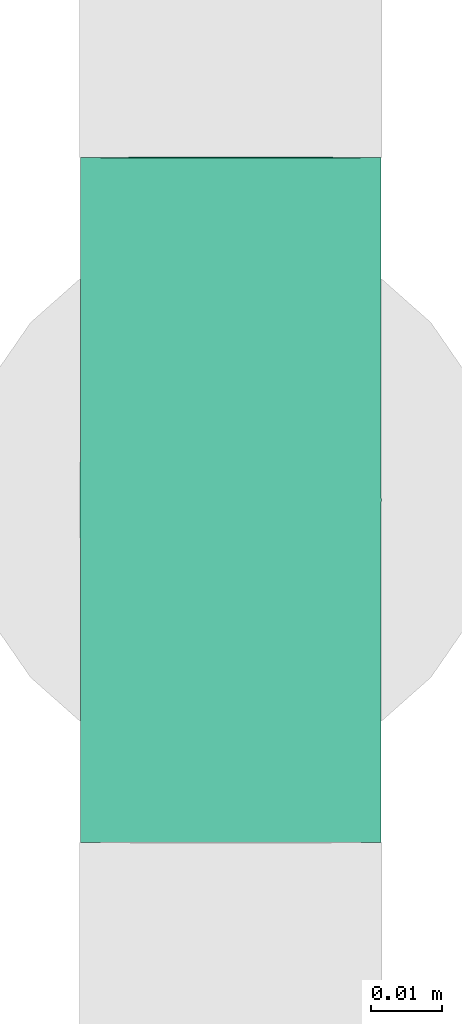
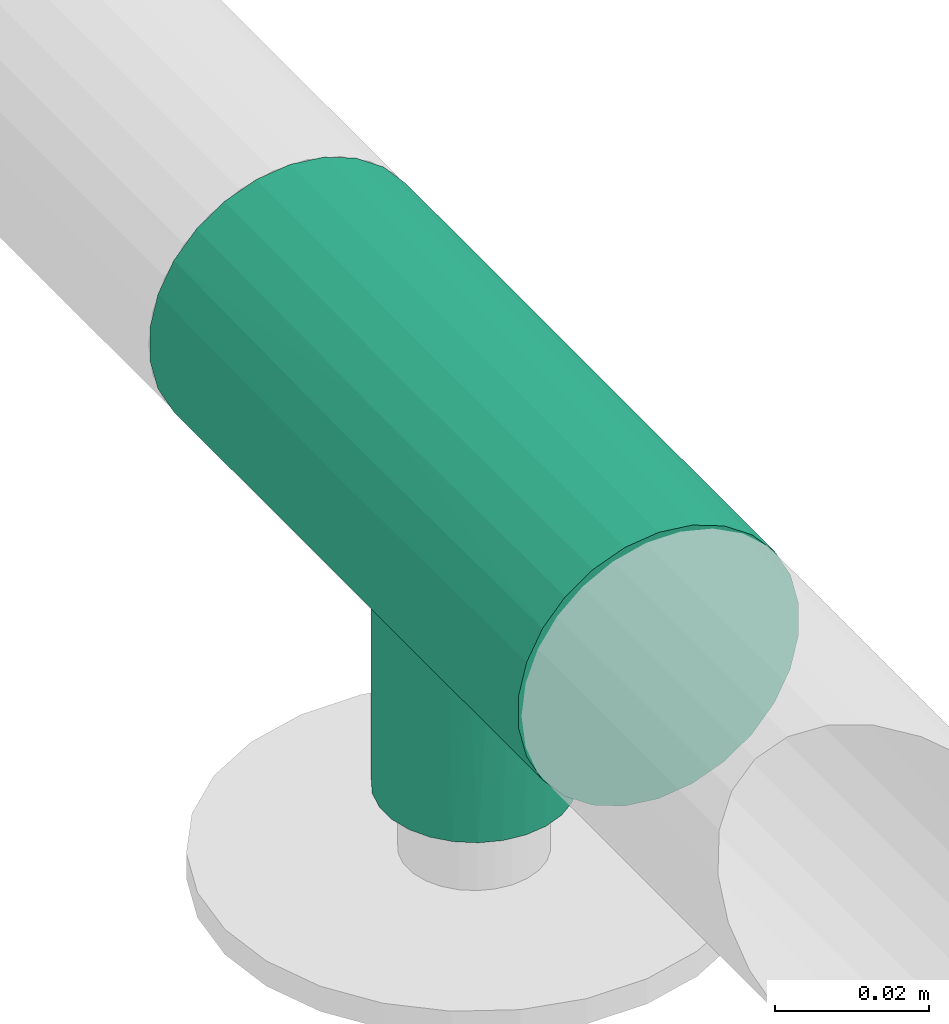
# One storey, part 6 of 7: 1 pipe fitting.
"""IFC4 building model written with IfcOpenShell, lengths in millimetres."""

from ifc_helpers import new_model, entity, si_unit, converted_unit, derived_unit, direction, frame, origin, place, context, subcontext, project, spatial, source, transform, mapped, type_object, type_shapes, element, save


model = new_model("IFC4")

# Units and contexts
model_context = context("Model", 3, precision=0.01, world=origin(), true_north=direction((6.12303176911189e-17, 1.0)))
body_context = subcontext(model_context, "Body", "Model", "MODEL_VIEW")
ifc_project = project(units=[si_unit("LENGTHUNIT", "METRE", prefix="MILLI"), si_unit("AREAUNIT", "SQUARE_METRE"), si_unit("VOLUMEUNIT", "CUBIC_METRE"), converted_unit("PLANEANGLEUNIT", "DEGREE", entity("IfcRatioMeasure", 0.0174532925199433), si_unit("PLANEANGLEUNIT", "RADIAN"), dimensions=[0, 0, 0, 0, 0, 0, 0]), si_unit("MASSUNIT", "GRAM", prefix="KILO"), derived_unit("MASSDENSITYUNIT", [(si_unit("MASSUNIT", "GRAM", prefix="KILO"), 1), (si_unit("LENGTHUNIT", "METRE"), -3)]), derived_unit("MOMENTOFINERTIAUNIT", [(si_unit("LENGTHUNIT", "METRE"), 4)]), si_unit("TIMEUNIT", "SECOND"), si_unit("FREQUENCYUNIT", "HERTZ"), si_unit("THERMODYNAMICTEMPERATUREUNIT", "DEGREE_CELSIUS"), derived_unit("THERMALTRANSMITTANCEUNIT", [(si_unit("MASSUNIT", "GRAM", prefix="KILO"), 1), (si_unit("THERMODYNAMICTEMPERATUREUNIT", "KELVIN"), -1), (si_unit("TIMEUNIT", "SECOND"), -3)]), derived_unit("VOLUMETRICFLOWRATEUNIT", [(si_unit("LENGTHUNIT", "METRE"), 3), (si_unit("TIMEUNIT", "SECOND"), -1)]), si_unit("ELECTRICCURRENTUNIT", "AMPERE"), si_unit("ELECTRICVOLTAGEUNIT", "VOLT"), si_unit("POWERUNIT", "WATT"), si_unit("FORCEUNIT", "NEWTON", prefix="KILO"), si_unit("ILLUMINANCEUNIT", "LUX"), si_unit("LUMINOUSFLUXUNIT", "LUMEN"), si_unit("LUMINOUSINTENSITYUNIT", "CANDELA"), derived_unit("USERDEFINED", [(si_unit("MASSUNIT", "GRAM", prefix="KILO"), -1), (si_unit("LENGTHUNIT", "METRE"), -2), (si_unit("TIMEUNIT", "SECOND"), 3), (si_unit("LUMINOUSFLUXUNIT", "LUMEN"), 1)]), derived_unit("LINEARVELOCITYUNIT", [(si_unit("LENGTHUNIT", "METRE"), 1), (si_unit("TIMEUNIT", "SECOND"), -1)]), si_unit("PRESSUREUNIT", "PASCAL"), derived_unit("USERDEFINED", [(si_unit("LENGTHUNIT", "METRE"), -2), (si_unit("MASSUNIT", "GRAM", prefix="KILO"), 1), (si_unit("TIMEUNIT", "SECOND"), -2)]), derived_unit("LINEARFORCEUNIT", [(si_unit("MASSUNIT", "GRAM", prefix="KILO"), 1), (si_unit("LENGTHUNIT", "METRE"), 1), (si_unit("TIMEUNIT", "SECOND"), -2), (si_unit("LENGTHUNIT", "METRE"), -1)]), derived_unit("PLANARFORCEUNIT", [(si_unit("MASSUNIT", "GRAM", prefix="KILO"), 1), (si_unit("LENGTHUNIT", "METRE"), 1), (si_unit("TIMEUNIT", "SECOND"), -2), (si_unit("LENGTHUNIT", "METRE"), -2)])], contexts=[model_context])

# Site, building, storey
site_placement = place(None, origin())
site = spatial("IfcSite", under=ifc_project, at=site_placement, CompositionType="ELEMENT")
building_placement = place(site_placement, origin())
building = spatial("IfcBuilding", under=site, at=building_placement, CompositionType="ELEMENT")
storey_placement = place(building_placement, origin())
storey = spatial("IfcBuildingStorey", under=building, at=storey_placement, Name="Ebene 1", CompositionType="ELEMENT", Elevation=0.0)

# Pipe fitting
pipe_fitting_type = type_object("IfcPipeFittingType", PredefinedType="NOTDEFINED")
cartesian_point_1 = entity("IfcCartesianPoint", [-48.0, -21.2, 0.0])
vertex_point_1 = entity("IfcVertexPoint", cartesian_point_1)
cartesian_point_2 = entity("IfcCartesianPoint", [-48.0, 21.2, 0.0])
vertex_point_2 = entity("IfcVertexPoint", cartesian_point_2)
cartesian_point_3 = entity("IfcCartesianPoint", [-48.0, 0.0, 0.0])
ifc_direction_1 = entity("IfcDirection", [-1.0, 0.0, 0.0])
ifc_direction_2 = entity("IfcDirection", [0.0, 1.0, 0.0])
edge_curve_1 = entity("IfcEdgeCurve", vertex_point_1, vertex_point_2, entity("IfcTrimmedCurve", entity("IfcCircle", entity("IfcAxis2Placement3D", cartesian_point_3, ifc_direction_1, ifc_direction_2), 21.2), [cartesian_point_1], [cartesian_point_2], True, "CARTESIAN"), True)
edge_curve_2 = entity("IfcEdgeCurve", vertex_point_2, vertex_point_1, entity("IfcTrimmedCurve", entity("IfcCircle", entity("IfcAxis2Placement3D", cartesian_point_3, ifc_direction_1, ifc_direction_2), 21.2), [cartesian_point_2], [cartesian_point_1], True, "CARTESIAN"), True)
ifc_direction_3 = entity("IfcDirection", [0.0, 0.0, 1.0])
cartesian_point_4 = entity("IfcCartesianPoint", [-13.5068310123159, -21.2, 0.0])
vertex_point_3 = entity("IfcVertexPoint", cartesian_point_4)
ifc_direction_4 = entity("IfcDirection", [1.0, 0.0, 0.0])
edge_curve_3 = entity("IfcEdgeCurve", vertex_point_1, vertex_point_3, entity("IfcTrimmedCurve", entity("IfcLine", cartesian_point_1, entity("IfcVector", ifc_direction_4, 304.8)), [cartesian_point_1], [cartesian_point_4], True, "CARTESIAN"), True)
cartesian_point_5 = entity("IfcCartesianPoint", [0.0, -16.3871726203176, 13.4499283831519])
vertex_point_4 = entity("IfcVertexPoint", cartesian_point_5)
edge_curve_4 = entity("IfcEdgeCurve", vertex_point_3, vertex_point_4, entity("IfcBSplineCurveWithKnots", 3, [cartesian_point_4, entity("IfcCartesianPoint", [-13.4993843279969, -21.2, 1.05794812747693]), entity("IfcCartesianPoint", [-13.2650422422083, -21.0434140195458, 3.11507359971931]), entity("IfcCartesianPoint", [-12.2097033278385, -20.3944142992724, 6.01796260768396]), entity("IfcCartesianPoint", [-10.5869775304879, -19.4602079881093, 8.53423591338198]), entity("IfcCartesianPoint", [-8.66670526622856, -18.4864516031954, 10.4322061778477]), entity("IfcCartesianPoint", [-7.07921954099315, -17.816195387073, 11.5004841657602]), entity("IfcCartesianPoint", [-6.09438216257907, -17.4642287426441, 12.019589804155]), entity("IfcCartesianPoint", [-5.42322870678574, -17.2441623058738, 12.3345472106217]), entity("IfcCartesianPoint", [-4.54456523880667, -16.9837518392907, 12.6913629495214]), entity("IfcCartesianPoint", [-3.45003040260097, -16.7226752567061, 13.0321080653307]), entity("IfcCartesianPoint", [-1.96306466831166, -16.4762970090604, 13.3423390087751]), entity("IfcCartesianPoint", [-0.797809125164616, -16.3935218506058, 13.4421925848803]), cartesian_point_5], "UNSPECIFIED", False, "UNKNOWN", [4, 1, 1, 1, 1, 1, 1, 1, 1, 1, 1, 4], [0.0, 0.142857142857143, 0.285714285714286, 0.428571428571429, 0.571428571428571, 0.678571428571429, 0.705357142857143, 0.732142857142857, 0.785714285714286, 0.839285714285714, 0.892857142857143, 1.0], "UNSPECIFIED"), True)
cartesian_point_6 = entity("IfcCartesianPoint", [0.0, 21.2, 0.0])
vertex_point_5 = entity("IfcVertexPoint", cartesian_point_6)
cartesian_point_7 = entity("IfcCartesianPoint", [0.0, 0.0, 0.0])
edge_curve_5 = entity("IfcEdgeCurve", vertex_point_4, vertex_point_5, entity("IfcTrimmedCurve", entity("IfcCircle", entity("IfcAxis2Placement3D", cartesian_point_7, ifc_direction_1, ifc_direction_2), 21.2), [cartesian_point_5], [cartesian_point_6], True, "CARTESIAN"), True)
edge_curve_6 = entity("IfcEdgeCurve", vertex_point_5, vertex_point_2, entity("IfcTrimmedCurve", entity("IfcLine", cartesian_point_2, entity("IfcVector", ifc_direction_1, 304.8)), [cartesian_point_6], [cartesian_point_2], True, "CARTESIAN"), True)
cartesian_point_8 = entity("IfcCartesianPoint", [0.0, -16.3871726203175, -13.449928383152])
vertex_point_6 = entity("IfcVertexPoint", cartesian_point_8)
edge_curve_7 = entity("IfcEdgeCurve", vertex_point_5, vertex_point_6, entity("IfcTrimmedCurve", entity("IfcCircle", entity("IfcAxis2Placement3D", cartesian_point_7, ifc_direction_1, ifc_direction_2), 21.2), [cartesian_point_6], [cartesian_point_8], True, "CARTESIAN"), True)
edge_curve_8 = entity("IfcEdgeCurve", vertex_point_6, vertex_point_3, entity("IfcBSplineCurveWithKnots", 3, [cartesian_point_8, entity("IfcCartesianPoint", [-0.531872750109738, -16.3914054405097, -13.4447711843042]), entity("IfcCartesianPoint", [-1.57730578727807, -16.4434169477037, -13.3815915248658]), entity("IfcCartesianPoint", [-3.08418265321333, -16.6431320654327, -13.1341373960215]), entity("IfcCartesianPoint", [-4.30469105163794, -16.9205920442628, -12.7756525430174]), entity("IfcCartesianPoint", [-5.24834595551357, -17.1912714137702, -12.4073699064933]), entity("IfcCartesianPoint", [-6.15681277657186, -17.4789123763263, -12.0018304329011]), entity("IfcCartesianPoint", [-7.23815152807533, -17.8821677528264, -11.400079892066]), entity("IfcCartesianPoint", [-8.84101892558636, -18.5742443265331, -10.2605108363264]), entity("IfcCartesianPoint", [-10.4100473231914, -19.3712289302309, -8.70890820400058]), entity("IfcCartesianPoint", [-11.6089388883376, -20.0461390578736, -6.95877821181811]), entity("IfcCartesianPoint", [-12.2887466198442, -20.4498827539783, -5.62338126500903]), entity("IfcCartesianPoint", [-12.7239014567574, -20.7130298608692, -4.56319870065523]), entity("IfcCartesianPoint", [-13.0721858144041, -20.9258467734263, -3.46027469079643]), entity("IfcCartesianPoint", [-13.3976136347692, -21.1329926195692, -1.96209851682803]), entity("IfcCartesianPoint", [-13.5012459990767, -21.2, -0.793461095607818]), cartesian_point_4], "UNSPECIFIED", False, "UNKNOWN", [4, 1, 1, 1, 1, 1, 1, 1, 1, 1, 1, 1, 1, 1, 4], [0.0, 0.0714285714285714, 0.142857142857143, 0.214285714285714, 0.25, 0.285714285714286, 0.357142857142857, 0.428571428571429, 0.571428571428571, 0.678571428571429, 0.732142857142857, 0.785714285714286, 0.839285714285714, 0.892857142857143, 1.0], "UNSPECIFIED"), True)
cartesian_point_9 = entity("IfcCartesianPoint", [48.0, -21.2, 0.0])
vertex_point_7 = entity("IfcVertexPoint", cartesian_point_9)
cartesian_point_10 = entity("IfcCartesianPoint", [48.0, 21.2, 0.0])
vertex_point_8 = entity("IfcVertexPoint", cartesian_point_10)
cartesian_point_11 = entity("IfcCartesianPoint", [48.0, 0.0, 0.0])
edge_curve_9 = entity("IfcEdgeCurve", vertex_point_7, vertex_point_8, entity("IfcTrimmedCurve", entity("IfcCircle", entity("IfcAxis2Placement3D", cartesian_point_11, ifc_direction_4, ifc_direction_2), 21.2), [cartesian_point_9], [cartesian_point_10], True, "CARTESIAN"), True)
edge_curve_10 = entity("IfcEdgeCurve", vertex_point_8, vertex_point_7, entity("IfcTrimmedCurve", entity("IfcCircle", entity("IfcAxis2Placement3D", cartesian_point_11, ifc_direction_4, ifc_direction_2), 21.2), [cartesian_point_10], [cartesian_point_9], True, "CARTESIAN"), True)
edge_curve_11 = entity("IfcEdgeCurve", vertex_point_8, vertex_point_5, entity("IfcTrimmedCurve", entity("IfcLine", cartesian_point_6, entity("IfcVector", ifc_direction_1, 304.8)), [cartesian_point_10], [cartesian_point_6], True, "CARTESIAN"), True)
cartesian_point_12 = entity("IfcCartesianPoint", [13.3932654778139, -21.2, 0.0])
vertex_point_9 = entity("IfcVertexPoint", cartesian_point_12)
edge_curve_12 = entity("IfcEdgeCurve", vertex_point_4, vertex_point_9, entity("IfcBSplineCurveWithKnots", 3, [cartesian_point_5, entity("IfcCartesianPoint", [0.530257095536676, -16.3943337327419, 13.441203400973]), entity("IfcCartesianPoint", [1.57180010559418, -16.4516475324037, 13.3715367567905]), entity("IfcCartesianPoint", [3.07119529071713, -16.6574671838955, 13.1160507991674]), entity("IfcCartesianPoint", [4.28327297063952, -16.9382144878634, 12.7523396286126]), entity("IfcCartesianPoint", [5.21947240729925, -17.2105237424157, 12.380675390749]), entity("IfcCartesianPoint", [6.12069079779092, -17.4992870805062, 11.9721563229298]), entity("IfcCartesianPoint", [7.19284133765075, -17.9027179259008, 11.3678283398922]), entity("IfcCartesianPoint", [8.78099413023988, -18.5933564401697, 10.2258784118188]), entity("IfcCartesianPoint", [10.3348278669528, -19.3867504595161, 8.6739793245556]), entity("IfcCartesianPoint", [11.520297599013, -20.0571184550339, 6.92670536768941]), entity("IfcCartesianPoint", [12.1920789492968, -20.4575766154143, 5.59508690266909]), entity("IfcCartesianPoint", [12.6215899962476, -20.7183625068992, 4.53856002259746]), entity("IfcCartesianPoint", [12.9650949288398, -20.9290532825325, 3.44023969891976]), entity("IfcCartesianPoint", [13.2860945293799, -21.1338876935633, 1.94963255657527]), entity("IfcCartesianPoint", [13.3880405623836, -21.2, 0.788124507325846]), cartesian_point_12], "UNSPECIFIED", False, "UNKNOWN", [4, 1, 1, 1, 1, 1, 1, 1, 1, 1, 1, 1, 1, 1, 4], [0.0, 0.0714285714285714, 0.142857142857143, 0.214285714285714, 0.25, 0.285714285714286, 0.357142857142857, 0.428571428571429, 0.571428571428571, 0.678571428571429, 0.732142857142857, 0.785714285714286, 0.839285714285714, 0.892857142857143, 1.0], "UNSPECIFIED"), True)
edge_curve_13 = entity("IfcEdgeCurve", vertex_point_9, vertex_point_7, entity("IfcTrimmedCurve", entity("IfcLine", cartesian_point_12, entity("IfcVector", ifc_direction_4, 304.8)), [cartesian_point_12], [cartesian_point_9], True, "CARTESIAN"), True)
edge_curve_14 = entity("IfcEdgeCurve", vertex_point_9, vertex_point_6, entity("IfcBSplineCurveWithKnots", 3, [cartesian_point_12, entity("IfcCartesianPoint", [13.3862989239068, -21.2, -1.0508326764346]), entity("IfcCartesianPoint", [13.1553973766308, -21.0455406919281, -3.09575670138564]), entity("IfcCartesianPoint", [12.1143892179346, -20.4028795469109, -5.98774639338692]), entity("IfcCartesianPoint", [10.5099767796447, -19.4753394710042, -8.49924586910733]), entity("IfcCartesianPoint", [8.60837676529961, -18.5059424550639, -10.3976335104358]), entity("IfcCartesianPoint", [7.03535379922459, -17.8368532321748, -11.4684907186413]), entity("IfcCartesianPoint", [6.05873418871356, -17.4844316709859, -11.9901942738029]), entity("IfcCartesianPoint", [5.39293772382854, -17.2636725741139, -12.3072557107247]), entity("IfcCartesianPoint", [4.52132894009119, -17.0018804638311, -12.6671261443141]), entity("IfcCartesianPoint", [3.43463038424665, -16.7380536632028, -13.012407562907]), entity("IfcCartesianPoint", [1.95592328379862, -16.4863400862022, -13.3300423037493]), entity("IfcCartesianPoint", [0.795385643305006, -16.397914288954, -13.4368409098836]), cartesian_point_8], "UNSPECIFIED", False, "UNKNOWN", [4, 1, 1, 1, 1, 1, 1, 1, 1, 1, 1, 4], [0.0, 0.142857142857143, 0.285714285714286, 0.428571428571429, 0.571428571428571, 0.678571428571429, 0.705357142857143, 0.732142857142857, 0.785714285714286, 0.839285714285714, 0.892857142857143, 1.0], "UNSPECIFIED"), True)
cartesian_point_13 = entity("IfcCartesianPoint", [-13.5785165111485, -47.9639752132051, 0.0])
vertex_point_10 = entity("IfcVertexPoint", cartesian_point_13)
cartesian_point_14 = entity("IfcCartesianPoint", [13.3213869990678, -48.0360247867948, 0.0])
vertex_point_11 = entity("IfcVertexPoint", cartesian_point_14)
cartesian_point_15 = entity("IfcCartesianPoint", [-0.128564756040346, -48.0, 0.0])
edge_curve_15 = entity("IfcEdgeCurve", vertex_point_10, vertex_point_11, entity("IfcTrimmedCurve", entity("IfcCircle", entity("IfcAxis2Placement3D", cartesian_point_15, entity("IfcDirection", [-0.00267842281002665, -0.999996413019192, 0.0]), entity("IfcDirection", [0.999996413019192, -0.00267842281002665, 0.0])), 13.45), [cartesian_point_13], [cartesian_point_14], True, "CARTESIAN"), True)
edge_curve_16 = entity("IfcEdgeCurve", vertex_point_11, vertex_point_10, entity("IfcTrimmedCurve", entity("IfcCircle", entity("IfcAxis2Placement3D", cartesian_point_15, entity("IfcDirection", [-0.00267842281002665, -0.999996413019192, 0.0]), entity("IfcDirection", [0.999996413019192, -0.00267842281002665, 0.0])), 13.45), [cartesian_point_14], [cartesian_point_13], True, "CARTESIAN"), True)
edge_curve_17 = entity("IfcEdgeCurve", vertex_point_11, vertex_point_9, entity("IfcTrimmedCurve", entity("IfcLine", cartesian_point_12, entity("IfcVector", entity("IfcDirection", [0.00267842281002664, 0.999996413019192, 0.0]), 304.8)), [cartesian_point_14], [cartesian_point_12], True, "CARTESIAN"), True)
edge_curve_18 = entity("IfcEdgeCurve", vertex_point_3, vertex_point_10, entity("IfcTrimmedCurve", entity("IfcLine", cartesian_point_4, entity("IfcVector", entity("IfcDirection", [-0.00267842281002664, -0.999996413019192, 0.0]), 304.8)), [cartesian_point_4], [cartesian_point_13], True, "CARTESIAN"), True)
shared_shape = source(origin(), body_context, "Body", "AdvancedBrep", [
    entity("IfcAdvancedBrep", entity("IfcClosedShell", [entity("IfcAdvancedFace", [entity("IfcFaceOuterBound", entity("IfcEdgeLoop", [entity("IfcOrientedEdge", None, None, edge_curve_1, True), entity("IfcOrientedEdge", None, None, edge_curve_2, True)]), True)], entity("IfcPlane", entity("IfcAxis2Placement3D", cartesian_point_3, ifc_direction_1, ifc_direction_3)), True), entity("IfcAdvancedFace", [entity("IfcFaceOuterBound", entity("IfcEdgeLoop", [entity("IfcOrientedEdge", None, None, edge_curve_1, False), entity("IfcOrientedEdge", None, None, edge_curve_3, True), entity("IfcOrientedEdge", None, None, edge_curve_4, True), entity("IfcOrientedEdge", None, None, edge_curve_5, True), entity("IfcOrientedEdge", None, None, edge_curve_6, True)]), True)], entity("IfcCylindricalSurface", entity("IfcAxis2Placement3D", cartesian_point_3, ifc_direction_1, ifc_direction_2), 21.2), True), entity("IfcAdvancedFace", [entity("IfcFaceOuterBound", entity("IfcEdgeLoop", [entity("IfcOrientedEdge", None, None, edge_curve_2, False), entity("IfcOrientedEdge", None, None, edge_curve_6, False), entity("IfcOrientedEdge", None, None, edge_curve_7, True), entity("IfcOrientedEdge", None, None, edge_curve_8, True), entity("IfcOrientedEdge", None, None, edge_curve_3, False)]), True)], entity("IfcCylindricalSurface", entity("IfcAxis2Placement3D", cartesian_point_3, ifc_direction_1, ifc_direction_2), 21.2), True), entity("IfcAdvancedFace", [entity("IfcFaceOuterBound", entity("IfcEdgeLoop", [entity("IfcOrientedEdge", None, None, edge_curve_9, True), entity("IfcOrientedEdge", None, None, edge_curve_10, True)]), True)], entity("IfcPlane", entity("IfcAxis2Placement3D", cartesian_point_11, ifc_direction_4, ifc_direction_3)), True), entity("IfcAdvancedFace", [entity("IfcFaceOuterBound", entity("IfcEdgeLoop", [entity("IfcOrientedEdge", None, None, edge_curve_10, False), entity("IfcOrientedEdge", None, None, edge_curve_11, True), entity("IfcOrientedEdge", None, None, edge_curve_5, False), entity("IfcOrientedEdge", None, None, edge_curve_12, True), entity("IfcOrientedEdge", None, None, edge_curve_13, True)]), True)], entity("IfcCylindricalSurface", entity("IfcAxis2Placement3D", cartesian_point_7, ifc_direction_1, ifc_direction_2), 21.2), True), entity("IfcAdvancedFace", [entity("IfcFaceOuterBound", entity("IfcEdgeLoop", [entity("IfcOrientedEdge", None, None, edge_curve_9, False), entity("IfcOrientedEdge", None, None, edge_curve_13, False), entity("IfcOrientedEdge", None, None, edge_curve_14, True), entity("IfcOrientedEdge", None, None, edge_curve_7, False), entity("IfcOrientedEdge", None, None, edge_curve_11, False)]), True)], entity("IfcCylindricalSurface", entity("IfcAxis2Placement3D", cartesian_point_7, ifc_direction_1, ifc_direction_2), 21.2), True), entity("IfcAdvancedFace", [entity("IfcFaceOuterBound", entity("IfcEdgeLoop", [entity("IfcOrientedEdge", None, None, edge_curve_15, True), entity("IfcOrientedEdge", None, None, edge_curve_16, True)]), True)], entity("IfcPlane", entity("IfcAxis2Placement3D", cartesian_point_15, entity("IfcDirection", [-0.00267842281002665, -0.999996413019192, 0.0]), ifc_direction_3)), True), entity("IfcAdvancedFace", [entity("IfcFaceOuterBound", entity("IfcEdgeLoop", [entity("IfcOrientedEdge", None, None, edge_curve_16, False), entity("IfcOrientedEdge", None, None, edge_curve_17, True), entity("IfcOrientedEdge", None, None, edge_curve_12, False), entity("IfcOrientedEdge", None, None, edge_curve_4, False), entity("IfcOrientedEdge", None, None, edge_curve_18, True)]), True)], entity("IfcCylindricalSurface", entity("IfcAxis2Placement3D", cartesian_point_7, entity("IfcDirection", [0.00267842281002665, 0.999996413019192, 0.0]), entity("IfcDirection", [0.999996413019192, -0.00267842281002665, 0.0])), 13.45), True), entity("IfcAdvancedFace", [entity("IfcFaceOuterBound", entity("IfcEdgeLoop", [entity("IfcOrientedEdge", None, None, edge_curve_15, False), entity("IfcOrientedEdge", None, None, edge_curve_18, False), entity("IfcOrientedEdge", None, None, edge_curve_8, False), entity("IfcOrientedEdge", None, None, edge_curve_14, False), entity("IfcOrientedEdge", None, None, edge_curve_17, False)]), True)], entity("IfcCylindricalSurface", entity("IfcAxis2Placement3D", cartesian_point_7, entity("IfcDirection", [0.00267842281002665, 0.999996413019192, 0.0]), entity("IfcDirection", [0.999996413019192, -0.00267842281002665, 0.0])), 13.45), True)])),
])
type_shapes(pipe_fitting_type, [shared_shape])
pipe_fitting_placement = place(storey_placement, frame((10168.2072507766, 95630.7019157326, 3020.71064385921), z_axis=(1.0, 0.0, 0.0), x_axis=(0.0, 0.999996413019192, 0.00267842281002672)))
element("IfcPipeFitting", 1, at=pipe_fitting_placement, inside=storey, type_object=pipe_fitting_type, PredefinedType="NOTDEFINED", context=body_context, shape_type="MappedRepresentation", body=[
    mapped(shared_shape, transform((0.0, 0.0, 0.0), scale=1.0)),
])

save(model, "model.ifc")
